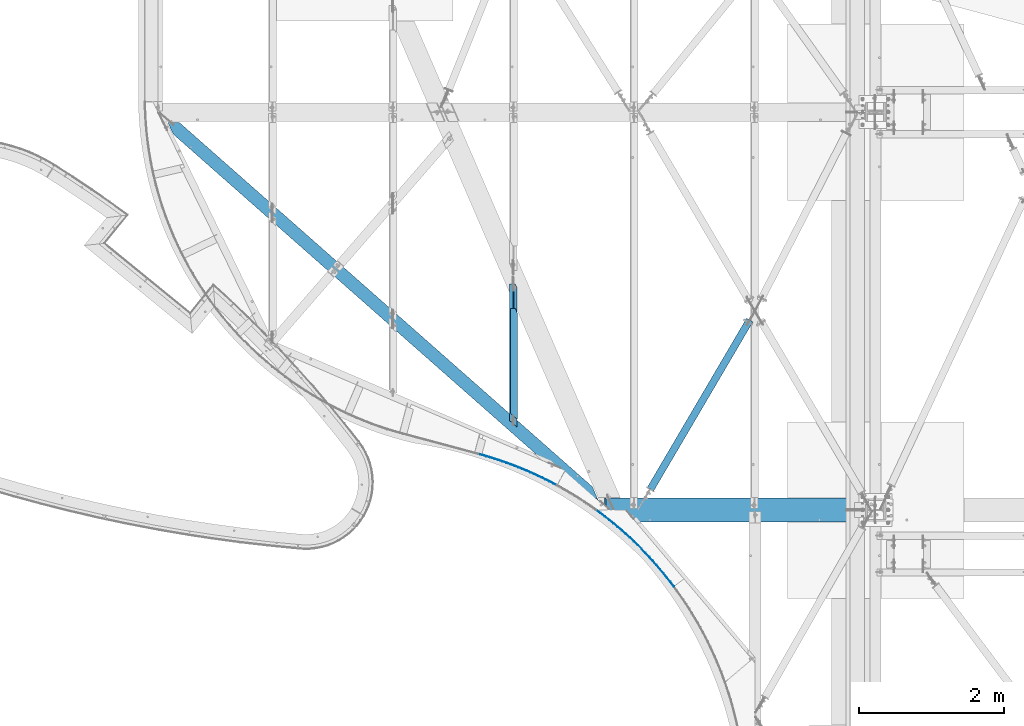
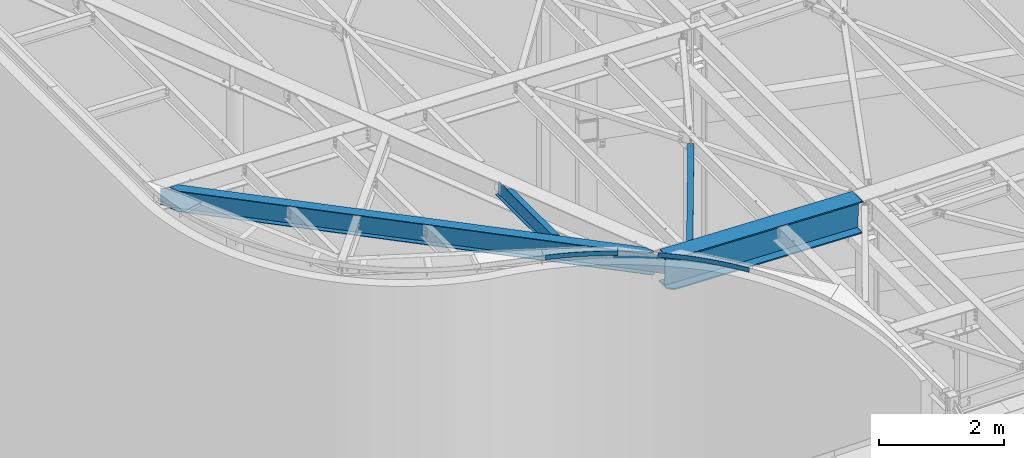
# One storey, part 1149 of 1763: 6 beams, 6 elements without a shape of their own.
"""IFC2X3 building model written with IfcOpenShell, lengths in millimetres."""

from ifc_helpers import new_model, si_unit, frame, origin_with_axes, place, context, subcontext, project, spatial, faceted_brep, material, type_object, element, aggregate, save


model = new_model("IFC2X3")

# Units and contexts
model_context = context("Model", 3, precision=1e-05, world=origin_with_axes())
body_context = subcontext(model_context, "Body", "Model", "MODEL_VIEW")
ifc_project = project(units=[si_unit("LENGTHUNIT", "METRE", prefix="MILLI"), si_unit("AREAUNIT", "SQUARE_METRE"), si_unit("VOLUMEUNIT", "CUBIC_METRE"), si_unit("MASSUNIT", "GRAM", prefix="KILO"), si_unit("TIMEUNIT", "SECOND"), si_unit("PLANEANGLEUNIT", "RADIAN"), si_unit("SOLIDANGLEUNIT", "STERADIAN"), si_unit("THERMODYNAMICTEMPERATUREUNIT", "DEGREE_CELSIUS"), si_unit("LUMINOUSINTENSITYUNIT", "LUMEN")], contexts=[model_context])

# Site, building, storey
site_placement = place(None, origin_with_axes())
site = spatial("IfcSite", under=ifc_project, at=site_placement, CompositionType="ELEMENT")
building_placement = place(site_placement, origin_with_axes())
building = spatial("IfcBuilding", under=site, at=building_placement, Name="Undefined", CompositionType="ELEMENT")
storey_placement = place(building_placement, origin_with_axes())
storey = spatial("IfcBuildingStorey", under=building, at=storey_placement, Name="Undefined", CompositionType="ELEMENT", Elevation=0.0)

# Assembly, beam
assembly_1_placement = place(storey_placement, origin_with_axes())
assembly_1 = element("IfcElementAssembly", 1, at=assembly_1_placement, inside=storey, Name="BEAM", AssemblyPlace="NOTDEFINED", PredefinedType="RIGID_FRAME")
ifc_material_1 = material(Name="STEEL/A36")
beam_type_1 = type_object("IfcBeamType", PredefinedType="NOTDEFINED")
beam_1_placement = place(assembly_1_placement, frame((-44076.1601975821, 58043.4401540759, 12604.723076646), z_axis=(0.0271919300984518, -0.0108512420392872, 0.999571332864106), x_axis=(-0.928378944769532, 0.370479937908028, 0.0292771329927325)))
beam_1 = element("IfcBeam", 2, at=beam_1_placement, type_object=beam_type_1, material=ifc_material_1, Name="PLATE", context=body_context, shape_type="Brep", body=[
    faceted_brep([(0.37272244070482, 3.15304661910341, -44.4500000000171), (0.372722440406505, 3.15304661916161, 44.4500000000189), (58.6961295197325, -3.39369225122209, 44.4500000000498), (58.6961295200308, -3.3936922512803, -44.449999999988), (-0.372722440682992, -3.15304661908885, 44.4500000000244), (-0.372722440391954, -3.15304661914706, -44.4500000000135), (58.0249346797864, -9.70811997567216, -44.4499999999862), (58.0249346794953, -9.70811997561395, 44.4500000000517), (117.092529157591, -9.25373598110309, 44.4500000000808), (117.092529157882, -9.25373598116857, -44.4499999999589), (116.495677283427, -15.5756239776601, -44.4499999999571), (116.495677283143, -15.5756239776019, 44.4500000000808), (175.553836543149, -14.4262732645802, 44.450000000108), (175.553836543448, -14.4262732646457, -44.4499999999298), (175.031410267206, -20.7547462863149, -44.4499999999261), (175.031410266914, -20.7547462862567, 44.4500000001117), (234.071957879387, -18.9105879789931, 44.4500000001372), (234.071957879678, -18.9105879790441, -44.4499999999007), (233.624029530023, -25.2447698673204, -44.449999999897), (233.624029529732, -25.2447698672549, 44.450000000139), (292.638791503487, -22.7060592840498, 44.4500000001644), (292.63879150377, -22.7060592841153, -44.4499999998734), (292.265423095079, -29.0450730900193, -44.4499999998716), (292.265423094774, -29.0450730899538, 44.4500000001699), (351.246229008568, -25.8121617078796, 44.4500000001935), (351.246229008859, -25.8121617079451, -44.4499999998443), (350.947472232881, -32.1551298135601, -44.4499999998407), (350.947472232598, -32.1551298135018, 44.4500000001954), (409.886156366287, -28.2284652196686, 44.4500000002208), (409.886156366585, -28.2284652197268, -44.449999999817), (409.662052585336, -34.5745094596787, -44.4499999998152), (409.662052585045, -34.5745094596205, 44.4500000002226), (468.550455050165, -29.9546352892576, 44.4500000002481), (468.550455050456, -29.9546352893231, -44.4499999997897), (468.401035290452, -36.3028770723322, -44.4499999997879), (468.401035290168, -36.3028770722667, 44.4500000002517), (527.231003159577, -30.9904329334604, 44.4500000002718), (527.231003159861, -30.9904329335259, -44.4499999997624), (527.156288107828, -37.3399933640758, -44.4499999997606), (527.156288107544, -37.3399933640103, 44.4500000002772), (585.91967654421, -31.3357147491188, 44.4500000003009), (585.919676544501, -31.3357147491843, -44.449999999737), (585.919676544516, -37.6857147491901, -44.4499999997333), (585.919676544225, -37.6857147491319, 44.4500000003045), (644.608349928851, -30.9904329329729, 44.4500000003263), (644.608349929127, -30.9904329330311, -44.4499999997115), (644.683064981189, -37.3399933635665, -44.4499999997079), (644.683064980905, -37.3399933635155, 44.45000000033), (703.288898038249, -29.954635288268, 44.4500000003518), (703.288898038532, -29.9546352883335, -44.449999999686), (703.438317798566, -36.3028770713281, -44.4499999996824), (703.438317798282, -36.3028770712772, 44.4500000003572), (761.953196722119, -28.228465218177, 44.4500000003773), (761.953196722403, -28.2284652182425, -44.4499999996606), (762.177300503681, -34.5745094581871, -44.4499999996569), (762.177300503383, -34.5745094581289, 44.4500000003809), (820.593124079824, -25.8121617058932, 44.4500000004027), (820.593124080129, -25.8121617059514, -44.4499999996351), (820.891880856121, -32.155129811581, -44.4499999996315), (820.89188085583, -32.1551298115155, 44.4500000004064), (879.200561584905, -22.706059281576, 44.4500000004282), (879.200561585181, -22.7060592816269, -44.4499999996115), (879.573929993909, -29.0450730875382, -44.4499999996078), (879.573929993625, -29.04507308748, 44.4500000004318), (937.767395208975, -18.91058797601, 44.45000000045), (937.767395209266, -18.9105879760755, -44.4499999995878), (938.21532355895, -25.2447698643446, -44.4499999995842), (938.215323558667, -25.2447698642864, 44.4500000004537), (996.285516545191, -14.4262732611169, 44.4500000004737), (996.285516545482, -14.4262732611824, -44.4499999995642), (996.807942821761, -20.7547462828443, -44.4499999995605), (996.807942821462, -20.7547462827861, 44.4500000004791), (1054.74682393074, -9.25373597714497, 44.4500000004973), (1054.74682393103, -9.25373597720318, -44.4499999995405), (1055.3436758055, -15.5756239736947, -44.4499999995369), (1055.34367580522, -15.575623973622, 44.4500000005009), (1113.14322356856, -3.39369224676193, 44.4500000005191), (1113.14322356886, -3.39369224682741, -44.4499999995187), (1113.81441840912, -9.708119971212, -44.4499999995132), (1113.81441840884, -9.70811997115379, 44.4500000005228), (1171.46663064788, 3.15304662410199, 44.4500000005428), (1171.46663064817, 3.15304662405106, -44.449999999495), (1172.21207552899, -3.15304661413393, 44.4500000005464), (1172.21207552927, -3.15304661418486, -44.4499999994914)], [[[0, 1, 2, 3]], [[4, 5, 6, 7]], [[5, 4, 1, 0]], [[3, 2, 8, 9]], [[7, 6, 10, 11]], [[9, 8, 12, 13]], [[11, 10, 14, 15]], [[13, 12, 16, 17]], [[15, 14, 18, 19]], [[17, 16, 20, 21]], [[19, 18, 22, 23]], [[21, 20, 24, 25]], [[23, 22, 26, 27]], [[25, 24, 28, 29]], [[27, 26, 30, 31]], [[29, 28, 32, 33]], [[31, 30, 34, 35]], [[33, 32, 36, 37]], [[35, 34, 38, 39]], [[37, 36, 40, 41]], [[39, 38, 42, 43]], [[41, 40, 44, 45]], [[43, 42, 46, 47]], [[45, 44, 48, 49]], [[47, 46, 50, 51]], [[49, 48, 52, 53]], [[51, 50, 54, 55]], [[53, 52, 56, 57]], [[55, 54, 58, 59]], [[57, 56, 60, 61]], [[59, 58, 62, 63]], [[61, 60, 64, 65]], [[63, 62, 66, 67]], [[65, 64, 68, 69]], [[67, 66, 70, 71]], [[69, 68, 72, 73]], [[71, 70, 74, 75]], [[73, 72, 76, 77]], [[75, 74, 78, 79]], [[77, 76, 80, 81]], [[76, 72, 68, 64, 60, 56, 52, 48, 44, 40, 36, 32, 28, 24, 20, 16, 12, 8, 2, 1, 4, 7, 11, 15, 19, 23, 27, 31, 35, 39, 43, 47, 51, 55, 59, 63, 67, 71, 75, 79, 82, 80]], [[79, 78, 83, 82]], [[78, 74, 70, 66, 62, 58, 54, 50, 46, 42, 38, 34, 30, 26, 22, 18, 14, 10, 6, 5, 0, 3, 9, 13, 17, 21, 25, 29, 33, 37, 41, 45, 49, 53, 57, 61, 65, 69, 73, 77, 81, 83]], [[82, 83, 81, 80]]]),
])
aggregate(assembly_1, [beam_1])

assembly_2_placement = place(storey_placement, origin_with_axes())
assembly_2 = element("IfcElementAssembly", 3, at=assembly_2_placement, inside=storey, Name="BEAM", AssemblyPlace="NOTDEFINED", PredefinedType="RIGID_FRAME")
beam_2_placement = place(assembly_2_placement, frame((-42460.3616705872, 56646.0617067743, 12556.9302582018), z_axis=(0.0159654027756333, -0.0157038897793027, 0.999749215433556), x_axis=(-0.712742688926495, 0.701068008927694, 0.0223943349976904)))
beam_2 = element("IfcBeam", 4, at=beam_2_placement, type_object=beam_type_1, material=ifc_material_1, Name="PLATE", context=body_context, shape_type="Brep", body=[
    faceted_brep([(0.479742981930031, 3.13854610777889, -44.4500000000335), (0.479742981900927, 3.13854610802628, 44.4500000000371), (75.3523089903028, -7.72566900236961, 44.4500000000189), (75.3523089903319, -7.725669002617, -44.4500000000553), (-0.479742981915479, -3.1385461077607, 44.4500000000371), (-0.479742981900927, -3.13854610800445, -44.4500000000335), (74.4881413791591, -14.0165921733478, -44.4500000000517), (74.48814137913, -14.0165921730986, 44.4500000000189), (150.381045438888, -17.4530025311287, 44.4499999999989), (150.381045438917, -17.4530025313725, -44.4500000000735), (149.612394996991, -23.7563093221306, -44.4500000000717), (149.612394996977, -23.7563093218832, 44.4499999999989), (225.548690678173, -26.0412165381058, 44.4499999999789), (225.548690678188, -26.0412165383459, -44.4500000000935), (224.875734246772, -32.355456765139, -44.4500000000917), (224.875734246743, -32.3554567648898, 44.4499999999807), (300.837951100373, -33.4883351571498, 44.4499999999571), (300.837951100402, -33.488335157399, -44.4500000001135), (300.260843504642, -39.8120561208107, -44.4500000001135), (300.260843504628, -39.8120561205742, 44.4499999999607), (376.231505118049, -39.7926450507439, 44.4499999999371), (376.231505118063, -39.7926450509931, -44.4500000001335), (375.750379131496, -46.1243918704131, -44.4500000001317), (375.750379131481, -46.1243918701712, 44.4499999999389), (451.712007149181, -44.952695804106, 44.4499999999152), (451.712007149195, -44.9526958043552, -44.4500000001535), (451.326973463118, -51.2910117526862, -44.4500000001517), (451.326973463103, -51.2910117524389, 44.4499999999171), (527.262091607903, -48.9673002589407, 44.4499999998952), (527.262091607918, -48.9673002591881, -44.4500000001754), (526.973238805949, -55.3107270979781, -44.4500000001717), (526.97323880592, -55.3107270977343, 44.449999999897), (602.864376899714, -51.8355347865381, 44.4499999998752), (602.864376899728, -51.83553478678, -44.4500000001972), (602.671771437381, -58.1826131017315, -44.4500000001972), (602.671771437366, -58.1826131014914, 44.449999999877), (678.501469420386, -53.5567395002818, 44.4499999998516), (678.501469420415, -53.5567395005291, -44.450000000219), (678.405155609929, -59.9060090372695, -44.4500000002154), (678.4051556099, -59.906009037024, 44.4499999998534), (754.155967557745, -54.1305184074736, 44.4499999998297), (754.155967557759, -54.1305184077137, -44.4500000002408), (754.155967557759, -60.4805184077341, -44.4500000002408), (754.155967557745, -60.4805184074867, 44.4499999998334), (829.810465695089, -53.5567395004055, 44.4499999998079), (829.810465695118, -53.5567395006528, -44.4500000002627), (829.906779505603, -59.9060090373878, -44.4500000002627), (829.906779505574, -59.9060090371459, 44.4499999998097), (905.447558215776, -51.8355347867873, 44.4499999997861), (905.44755821579, -51.8355347870274, -44.4500000002863), (905.640163678123, -58.1826131019789, -44.4500000002827), (905.640163678094, -58.1826131017388, 44.4499999997861), (981.049843507586, -48.9673002593172, 44.4499999997624), (981.049843507601, -48.9673002595591, -44.45000000031), (981.338696309584, -55.3107270983455, -44.4500000003063), (981.338696309569, -55.3107270981018, 44.4499999997643), (1056.59992796632, -44.9526958046099, 44.4499999997388), (1056.59992796634, -44.9526958048518, -44.4500000003336), (1056.9849616524, -51.2910117531737, -44.45000000033), (1056.98496165239, -51.2910117529336, 44.4499999997406), (1132.08042999746, -39.7926450513642, 44.449999999717), (1132.08042999747, -39.7926450516061, -44.4500000003554), (1132.56155598404, -46.1243918710334, -44.4500000003536), (1132.56155598401, -46.1243918707987, 44.4499999997151), (1207.47398401513, -33.4883351578937, 44.4499999996915), (1207.47398401516, -33.4883351581411, -44.4500000003791), (1208.05109161089, -39.8120561215565, -44.4500000003791), (1208.05109161088, -39.8120561213145, 44.4499999996933), (1282.76324443734, -26.0412165389589, 44.4499999996697), (1282.76324443736, -26.0412165392154, -44.4500000004045), (1283.43620086879, -32.3554567659994, -44.4500000004009), (1283.43620086877, -32.3554567657575, 44.4499999996697), (1357.93088967665, -17.4530025321092, 44.4499999996442), (1357.93088967667, -17.4530025323584, -44.4500000004264), (1358.69954011858, -23.7563093231165, -44.4500000004264), (1358.69954011856, -23.7563093228691, 44.4499999996442), (1432.95962612524, -7.72566900348102, 44.4499999996187), (1432.95962612526, -7.72566900372294, -44.4500000004518), (1433.82379373642, -14.0165921744519, -44.45000000045), (1433.8237937364, -14.01659217421, 44.4499999996206), (1507.83219213366, 3.13854610679118, 44.4499999995951), (1507.83219213369, 3.13854610654926, -44.4500000004773), (1508.79167809749, -3.13854610898852, 44.4499999995969), (1508.79167809751, -3.13854610923772, -44.4500000004755)], [[[0, 1, 2, 3]], [[4, 5, 6, 7]], [[5, 4, 1, 0]], [[3, 2, 8, 9]], [[7, 6, 10, 11]], [[9, 8, 12, 13]], [[11, 10, 14, 15]], [[13, 12, 16, 17]], [[15, 14, 18, 19]], [[17, 16, 20, 21]], [[19, 18, 22, 23]], [[21, 20, 24, 25]], [[23, 22, 26, 27]], [[25, 24, 28, 29]], [[27, 26, 30, 31]], [[29, 28, 32, 33]], [[31, 30, 34, 35]], [[33, 32, 36, 37]], [[35, 34, 38, 39]], [[37, 36, 40, 41]], [[39, 38, 42, 43]], [[41, 40, 44, 45]], [[43, 42, 46, 47]], [[45, 44, 48, 49]], [[47, 46, 50, 51]], [[49, 48, 52, 53]], [[51, 50, 54, 55]], [[53, 52, 56, 57]], [[55, 54, 58, 59]], [[57, 56, 60, 61]], [[59, 58, 62, 63]], [[61, 60, 64, 65]], [[63, 62, 66, 67]], [[65, 64, 68, 69]], [[67, 66, 70, 71]], [[69, 68, 72, 73]], [[71, 70, 74, 75]], [[73, 72, 76, 77]], [[75, 74, 78, 79]], [[77, 76, 80, 81]], [[76, 72, 68, 64, 60, 56, 52, 48, 44, 40, 36, 32, 28, 24, 20, 16, 12, 8, 2, 1, 4, 7, 11, 15, 19, 23, 27, 31, 35, 39, 43, 47, 51, 55, 59, 63, 67, 71, 75, 79, 82, 80]], [[79, 78, 83, 82]], [[78, 74, 70, 66, 62, 58, 54, 50, 46, 42, 38, 34, 30, 26, 22, 18, 14, 10, 6, 5, 0, 3, 9, 13, 17, 21, 25, 29, 33, 37, 41, 45, 49, 53, 57, 61, 65, 69, 73, 77, 81, 83]], [[82, 83, 81, 80]]]),
])
aggregate(assembly_2, [beam_2])

assembly_3_placement = place(storey_placement, origin_with_axes())
assembly_3 = element("IfcElementAssembly", 5, at=assembly_3_placement, inside=storey, Name="H. BRACE", AssemblyPlace="NOTDEFINED", PredefinedType="RIGID_FRAME")
ifc_material_2 = material()
beam_type_2 = type_object("IfcBeamType", Name="HSS4X4X3/8", PredefinedType="NOTDEFINED")
beam_3_placement = place(assembly_3_placement, frame((-41338.5382217807, 60452.3469434345, 12371.3875), z_axis=(0.0, 0.0, 1.0), x_axis=(-0.506427012963701, -0.862282830943921, 8.119604899548e-11)))
beam_3 = element("IfcBeam", 6, at=beam_3_placement, type_object=beam_type_2, material=ifc_material_2, Name="H. BRACE", ObjectType="HSS4X4X3/8", context=body_context, shape_type="Brep", body=[
    faceted_brep([(142.920826766138, 6.34999999808497, 50.7999999999993), (142.920826766138, 6.34999999808497, 41.2749999999996), (227.102923085011, 6.34999999820138, 41.2749999999996), (227.102923085011, 6.34999999820138, 50.7999999999993), (227.102923085029, -6.35000000166474, 50.7999999999993), (227.102923085029, -6.35000000166474, 41.2749999999996), (142.920826766131, -6.35000000178115, 41.2749999999996), (142.920826766131, -6.35000000178115, 50.7999999999993), (142.920826766138, 6.34999999808497, -41.2749999999996), (142.920826766138, 6.34999999808497, -50.7999999999993), (227.102923085011, 6.34999999820138, -50.7999999999993), (227.102923085011, 6.34999999820138, -41.2749999999996), (227.102923085029, -6.35000000166474, -41.2749999999996), (227.102923085029, -6.35000000166474, -50.7999999999993), (142.920826766131, -6.35000000178115, -50.7999999999993), (142.920826766131, -6.35000000178115, -41.2749999999996), (142.920826766134, -41.2749999996595, -41.2749999999996), (142.920826766134, -41.2749999996595, 41.2749999999996), (2852.87631211097, -41.2749999956577, 41.2749999999996), (2852.87631212352, -41.2749999956577, -41.2749999999996), (142.920826766134, 50.8000000000175, -50.7999999999993), (2852.87631210215, 50.8000000040192, -50.7999999999993), (2852.87631212734, -50.7999999956228, -50.7999999999993), (142.920826766138, -50.7999999996246, -50.7999999999993), (142.920826766138, -50.7999999996246, 50.7999999999993), (2852.87631211188, -50.7999999956228, 50.7999999999993), (142.920826766138, 41.2750000000524, 41.2749999999996), (2852.87631209051, 41.2750000040542, 41.2749999999996), (142.920826766138, 41.2750000000524, -41.2749999999996), (2852.87631210307, 41.2750000040396, -41.2749999999996), (2852.8763120867, 50.8000000040192, 50.7999999999993), (142.920826766134, 50.8000000000175, 50.7999999999993)], [[[0, 1, 2, 3]], [[4, 5, 6, 7]], [[3, 2, 5, 4]], [[8, 9, 10, 11]], [[12, 13, 14, 15]], [[11, 10, 13, 12]], [[16, 17, 18, 19]], [[9, 20, 21, 22, 23, 14, 13, 10]], [[24, 23, 22, 25]], [[17, 16, 15, 14, 23, 24, 7, 6]], [[1, 26, 27, 18, 17, 6, 5, 2]], [[26, 28, 29, 27]], [[25, 22, 21, 30], [18, 27, 29, 19]], [[20, 31, 30, 21]], [[24, 25, 30, 31, 0, 3, 4, 7]], [[31, 20, 9, 8, 28, 26, 1, 0]], [[16, 19, 29, 28, 8, 11, 12, 15]]]),
])
aggregate(assembly_3, [beam_3])

assembly_4_placement = place(storey_placement, origin_with_axes())
assembly_4 = element("IfcElementAssembly", 7, at=assembly_4_placement, inside=storey, Name="BEAM", AssemblyPlace="NOTDEFINED", PredefinedType="RIGID_FRAME")
ifc_material_3 = material(Name="STEEL/A992")
beam_type_3 = type_object("IfcBeamType", Name="W12X16", PredefinedType="NOTDEFINED")
beam_4_placement = place(assembly_4_placement, frame((-44674.7062632819, 58861.9920557196, 12440.7807458876), z_axis=(0.0294363099980619, 0.0, 0.999566657934176), x_axis=(0.0, 1.0, 0.0)))
beam_4 = element("IfcBeam", 8, at=beam_4_placement, type_object=beam_type_3, material=ifc_material_3, Name="BEAM", ObjectType="W12X16", context=body_context, shape_type="Brep", body=[
    faceted_brep([(27.1730545144965, -3.17500000023574, -146.050000000021), (-14.8073242350511, -50.8000000002357, -146.050000000032), (1911.81464084861, -50.800000000243, -146.050000000032), (1964.86248700026, -27.8473339844277, -146.050000000027), (1964.86248707807, -3.17500000023574, -146.050000000021), (1912.24683605041, -50.8000000002576, -152.400000000034), (1964.86248699884, -28.0343355853038, -152.400000000027), (-14.6424864781366, -50.8000000002576, -152.400000000032), (74.9156548542305, 50.7999999997774, -152.400000000003), (1964.86248707807, 50.7999999997701, -152.400000000005), (74.750817097316, 50.7999999997846, -146.050000000005), (1964.86248707807, 50.7999999997774, -146.050000000007), (32.7704383477685, 3.17499999977008, -146.050000000016), (1964.86248707807, 3.17499999977008, -146.050000000017), (1964.86248707807, -3.17499999985012, 105.768943687039), (1964.86248707807, 3.17500000016298, 105.768943685984), (1710.62031132146, 3.17500000014843, 105.768943667044), (1695.94428971591, -3.17499999985012, 105.76894366703), (1637.63228058851, 3.17500000015571, 105.653973909424), (1637.63228058851, -3.17499999985012, 105.84097551356), (1632.77220107046, 3.17500000016298, 106.621122938368), (1632.77220107046, -3.17499999985012, 106.808124542506), (1628.65202460231, 3.17500000016298, 109.375330352777), (1628.65202460231, -3.17499999984284, 109.562331956917), (1625.89901070183, 3.17500000017026, 113.49729304076), (1625.89901070183, -3.17499999983556, 113.684294644896), (1624.93228077924, 3.17500000017753, 118.359479548752), (1624.93228077924, -3.17499999982829, 118.546481152889), (1624.93228077924, -19.0582654763712, 152.400000000009), (1624.93228077924, -19.2452669173072, 146.050000000008), (1624.93228077924, -3.17499999978463, 146.050000000014), (1624.93228077924, 3.17500000022119, 146.050000000016), (1624.93228077924, 50.8000000002285, 146.050000000028), (1624.93228077924, 50.8000000002357, 152.400000000031), (1551.57127579318, -50.7999999997846, 152.400000000001), (1552.00347062581, -50.7999999997919, 146.050000000001), (90.8485894317782, -50.7999999997919, 146.050000000003), (132.828968223388, -3.17499999978463, 146.050000000014), (128.511618550168, -3.17499999982101, 116.799783999275), (122.97933166672, -3.17499999982829, 113.982716170298), (116.424579717423, -3.17499999983556, 112.992190041163), (20.4486541345759, -3.17499999983556, 112.992190018374), (133.351013806983, -3.17499999981374, 125.939452173789), (132.158467960624, -3.17499999982829, 121.003963712421), (26.046037967848, 3.17500000016298, 112.992190018369), (122.021963556334, 3.17500000016298, 112.992190041179), (128.576715505638, 3.17500000017026, 113.982716170316), (134.109002389087, 3.17500000017753, 116.799783999293), (137.755851799535, 3.17500000018481, 121.003963712441), (138.948397645894, 3.17500000018481, 125.939452173809), (138.426352062263, 3.17500000022119, 146.050000000017), (180.406730853872, 50.8000000002285, 146.05000000003), (180.241892811471, 50.800000000243, 152.400000000031), (90.6837513893697, -50.7999999997774, 152.400000000001)], [[[0, 1, 2, 3, 4]], [[2, 5, 6, 3]], [[1, 7, 5, 2]], [[5, 7, 8, 9, 6]], [[8, 10, 11, 9]], [[10, 12, 13, 11]], [[14, 4, 3, 6, 9, 11, 13, 15]], [[16, 17, 14, 15]], [[16, 18, 19, 17]], [[19, 18, 20, 21]], [[21, 20, 22, 23]], [[23, 22, 24, 25]], [[25, 24, 26, 27]], [[28, 29, 30, 27, 26, 31, 32, 33]], [[34, 35, 29, 28]], [[30, 29, 35, 36, 37]], [[38, 39, 40, 41, 0, 4, 14, 17, 19, 21, 23, 25, 27, 30, 37, 42, 43]], [[12, 10, 8, 7, 1, 0, 41, 44]], [[31, 26, 24, 22, 20, 18, 16, 15, 13, 12, 44, 45, 46, 47, 48, 49, 50]], [[32, 31, 50, 51]], [[33, 32, 51, 52]], [[34, 28, 33, 52, 53]], [[35, 34, 53, 36]], [[52, 51, 50, 49, 42, 37, 36, 53]], [[48, 43, 42, 49]], [[47, 38, 43, 48]], [[46, 39, 38, 47]], [[45, 40, 39, 46]], [[44, 41, 40, 45]]]),
])
aggregate(assembly_4, [beam_4])

assembly_5_placement = place(storey_placement, origin_with_axes())
assembly_5 = element("IfcElementAssembly", 9, at=assembly_5_placement, inside=storey, Name="BEAM", AssemblyPlace="NOTDEFINED", PredefinedType="RIGID_FRAME")
beam_type_4 = type_object("IfcBeamType", Name="W16X36", PredefinedType="NOTDEFINED")
beam_5_placement = place(assembly_5_placement, frame((-43358.6753845393, 57705.393281964, 12352.9819299811), z_axis=(0.0165544522142809, -0.0145987081889616, 0.99975638424123), x_axis=(-0.749838560163777, 0.661252570144429, 0.0220719770048209)))
beam_5 = element("IfcBeam", 10, at=beam_5_placement, type_object=beam_type_4, material=ifc_material_3, Name="BEAM", ObjectType="W16X36", context=body_context, shape_type="Brep", body=[
    faceted_brep([(7999.04018268338, -88.899999980722, 190.499999994219), (7999.28551865312, -88.8999999807147, 201.612499994215), (386.348753589147, -88.8999998248855, 201.612499999657), (386.103418977349, -88.8999999991411, 190.49999999966), (8095.37288130054, -3.96874998026942, 190.499999994145), (225.161345003304, -13.1705553453066, 190.499999999771), (235.598430784783, -3.96874999928332, 190.499999999762), (8119.69876574878, 17.2617643462636, 201.612500182286), (8119.45343906732, 17.2617553538312, 190.499999994125), (7957.0318708312, 88.900000019632, 190.499999994234), (7957.27720543661, 88.9000000196393, 201.612499994233), (8094.91940933664, -3.96874998028761, 169.959974013045), (8103.92246528206, 3.96875001974877, 169.959974010482), (8104.37593724606, 3.9687500197706, 190.499999994136), (8096.29977190316, -3.96874998028761, 165.043251861232), (8105.30282784857, 3.96875001974877, 165.043251858668), (8100.44330195121, -3.96874998027852, 160.860104844047), (8109.44635789662, 3.96875001976514, 160.860104841482), (8106.70755885169, -3.96874998026033, 158.059116070595), (8115.71061479711, 3.96875001977241, 158.059116068031), (8114.12129029146, -3.96874998025123, 157.07456958584), (8123.12434623686, 3.96875001979606, 157.074569583277), (8263.88758788217, -3.96874997988925, 157.074569539136), (8263.88759195128, 3.9687500201253, 157.074569539438), (8256.6037776498, -3.96874998016392, -172.847652026432), (8256.60378181422, 3.96875001986518, -172.847652025941), (8106.27672208511, -3.96874998052408, -172.847651976424), (8115.27977803053, 3.96875001951958, -172.847651978989), (8098.99250155895, -3.96874998054409, -173.796721664226), (8107.99555750437, 3.96875001949047, -173.796721666789), (8092.79697914574, -3.96874998056228, -176.502082970421), (8101.80003509115, 3.9687500194741, -176.502082972986), (8088.61613636126, -3.96874998057501, -180.559393146166), (8097.61919230669, 3.96875001946864, -180.559393148729), (8087.07484111509, -3.96874998058411, -185.362247440413), (8096.0778970605, 3.96875001945955, -185.362247442976), (204.558658193215, -4.26887409769188, -190.500000000069), (204.558658193127, -4.26862904997324, -201.612500000065), (206.06059523049, -4.26850665126221, -201.612500000068), (206.050786816108, -4.26875170736457, -190.500000000073), (206.050787527827, -8.13622363110699, -190.500000000071), (206.060595964314, -8.25627826176242, -201.612500000067), (377.446611961408, -88.8999999994649, -201.612500000183), (377.691946573192, -88.8999997253322, -190.500000000187), (7990.38337843654, -88.8999999810494, -201.612500005625), (7990.62871404536, -88.8999999810421, -190.500000005628), (204.558638685281, 88.9000000005799, -190.50000000008), (204.558638685165, 88.9000000005726, -201.612500000072), (204.558653613116, 4.26887402189823, -201.612500000067), (204.558653613203, 4.26862897416504, -190.500000020522), (7948.62039864589, 88.9000000193173, -190.500000005613), (7948.37506404048, 88.9000000193064, -201.612500005609), (8111.04195873337, 17.2617644458169, -190.499999793217), (8110.79663331233, 17.261754023848, -201.612500005718), (8095.96446860807, 3.96875001945045, -190.500000005712), (8086.96141266254, -3.96874998058956, -190.500000005704), (34.5753560719895, 3.96875000022374, 150.162470500145), (25.5723001197912, -3.96874999982538, 150.162470494739), (215.461432358235, -3.96874999936335, 148.328997731), (224.464488310419, 3.96875000067848, 148.328997736362), (222.831014649331, -3.96874999934516, 149.224673752045), (231.83407060153, 3.96875000069122, 149.224673757408), (229.121325973858, -3.96874999933061, 151.917245020733), (238.124381926071, 3.96875000071304, 151.917245026098), (233.374723454486, -3.9687499993197, 155.996791969625), (242.377779406685, 3.96875000072396, 155.996791974987), (234.943665881903, -3.96874999930697, 160.842240556936), (243.946721834101, 3.96875000073305, 160.842240562301), (27.0544295437867, 3.9687499999327, -190.499999999944), (244.601486736923, 3.96875000076034, 190.499999999753), (340.934185424878, 88.9000000012184, 190.499999999678), (341.17952003995, 88.9000000012184, 201.612499999675), (225.406679626569, -13.1705553378124, 201.612499986872), (18.2751391518541, -3.96875000010004, -180.364476371611), (18.0513735917193, -3.96875000010732, -190.499999999938), (18.2507197654631, -4.26890696070041, -190.499999999938), (18.2605281798169, -4.26866191128101, -201.612499999934), (27.1494730871345, 4.26884272913594, -201.612499999939), (18.2605280508869, -3.56805194320077, -201.612499999934), (27.3945298074686, 4.26859772468015, -190.499999999944)], [[[0, 1, 2, 3]], [[4, 0, 3, 5, 6]], [[7, 8, 9, 10]], [[1, 0, 4, 11, 12, 13, 8, 7]], [[12, 11, 14, 15]], [[15, 14, 16, 17]], [[17, 16, 18, 19]], [[19, 18, 20, 21]], [[21, 20, 22, 23]], [[22, 24, 25, 23]], [[26, 27, 25, 24]], [[27, 26, 28, 29]], [[29, 28, 30, 31]], [[31, 30, 32, 33]], [[33, 32, 34, 35]], [[36, 37, 38, 39]], [[40, 39, 38, 41]], [[42, 43, 40, 41]], [[44, 45, 43, 42]], [[46, 47, 48, 49]], [[50, 51, 47, 46]], [[52, 53, 51, 50]], [[54, 35, 34, 55, 45, 44, 53, 52]], [[56, 57, 58, 59]], [[59, 58, 60, 61]], [[61, 60, 62, 63]], [[63, 62, 64, 65]], [[65, 64, 66, 67]], [[13, 12, 15, 17, 19, 21, 23, 25, 27, 29, 31, 33, 35, 54, 68, 56, 59, 61, 63, 65, 67, 69]], [[9, 8, 13, 69, 70]], [[10, 9, 70, 71]], [[2, 1, 7, 10, 71, 72]], [[3, 2, 72, 5]], [[71, 70, 69, 67, 66, 6, 5, 72]], [[64, 62, 60, 58, 57, 73, 74, 55, 34, 32, 30, 28, 26, 24, 22, 20, 18, 16, 14, 11, 4, 6, 66]], [[36, 39, 40, 43, 45, 55, 74, 75]], [[37, 36, 75, 76]], [[77, 48, 47, 51, 53, 44, 42, 41, 38, 37, 76, 78]], [[75, 74, 78, 76]], [[73, 57, 56, 68, 79, 77, 78, 74]], [[49, 48, 77, 79]], [[68, 54, 52, 50, 46, 49, 79]]]),
])
aggregate(assembly_5, [beam_5])

assembly_6_placement = place(storey_placement, origin_with_axes())
assembly_6 = element("IfcElementAssembly", 11, at=assembly_6_placement, inside=storey, Name="BEAM", AssemblyPlace="NOTDEFINED", PredefinedType="RIGID_FRAME")
beam_type_5 = type_object("IfcBeamType", Name="W24X131", PredefinedType="NOTDEFINED")
beam_6_placement = place(assembly_6_placement, frame((-43410.4416198229, 57702.4499999993, 12244.597385134), z_axis=(0.0307657629960085, 0.0, 0.99952662187021), x_axis=(0.99952662187021, 0.0, -0.0307657629960041)))
beam_6 = element("IfcBeam", 12, at=beam_6_placement, type_object=beam_type_5, material=ifc_material_3, Name="BEAM", ObjectType="W24X131", context=body_context, shape_type="Brep", body=[
    faceted_brep([(1.23691279441118e-10, -7.9375, 287.337500000016), (3562.77092357731, -7.9375, 287.337499998226), (3562.77092357731, -163.512499999997, 287.337499998226), (86.2666237430094, -163.512499999997, 287.337499999972), (1.23691279441118e-10, -95.5449047368529, 287.337500000016), (-1.30967237055302e-10, -7.9375, -287.337500000012), (3555.41392490582, -7.9375, -287.337500001797), (3571.6131740351, -7.9375, -287.337500001806), (3571.97956562866, -163.512499999997, -311.150000001806), (3571.97956562866, 163.512499999997, -311.150000001806), (3571.86269849852, 163.512499999997, -303.554578639669), (3571.86269849852, -163.512499999997, -303.554578639669), (-1.45519152283669e-10, 163.512499999997, -311.150000000014), (104.688268726779, -163.512499999997, -311.150000000067), (-1.45519152283669e-10, -81.0308915990754, -311.150000000014), (-1.30967237055302e-10, 163.512499999997, -287.337500000012), (3555.41392490582, 163.512499999997, -287.337500001797), (-1.30967237055302e-10, 7.9375, -287.337500000012), (3555.41392490582, 7.9375, -287.337500001797), (3555.41392490582, -163.512499999997, -287.337500001797), (3571.6131740351, 7.9375, -287.337500001806), (1.23691279441118e-10, 7.9375, 287.337500000016), (3562.77092357731, 7.9375, 287.337499998226), (1.23691279441118e-10, 163.512499999997, 287.337500000016), (3562.77092357731, 163.512499999997, 287.337499998226), (3562.6488980457, 163.512499999997, 295.268175872261), (3562.6488980457, -163.512499999997, 295.268175872261), (3546.54734451455, 163.512499999997, 311.149999998237), (3546.54734451455, -163.512499999997, 311.149999998237), (1.30967237055302e-10, 163.512499999997, 311.150000000016), (1.30967237055302e-10, -96.1223853656775, 311.150000000016), (85.5336670460456, -163.512499999997, 311.149999999974), (-1.30967237055302e-10, -81.6083722279, -287.337500000012), (103.955312029808, -163.512499999997, -287.337500000063)], [[[0, 1, 2, 3, 4]], [[1, 0, 5, 6, 7]], [[8, 9, 10, 11]], [[12, 9, 8, 13, 14]], [[9, 12, 15, 16, 10]], [[15, 17, 18, 16]], [[11, 10, 16, 18, 6, 19]], [[7, 6, 18, 20]], [[17, 21, 22, 20, 18]], [[21, 23, 24, 22]], [[2, 1, 7, 20, 22, 24, 25, 26]], [[26, 25, 27, 28]], [[24, 23, 29, 27, 25]], [[28, 27, 29, 30, 31]], [[2, 26, 28, 31, 3]], [[30, 4, 3, 31]], [[29, 23, 21, 17, 15, 12, 14, 32, 5, 0, 4, 30]], [[19, 6, 5, 32, 33]], [[8, 11, 19, 33, 13]], [[32, 14, 13, 33]]]),
])
aggregate(assembly_6, [beam_6])

save(model, "model.ifc")
